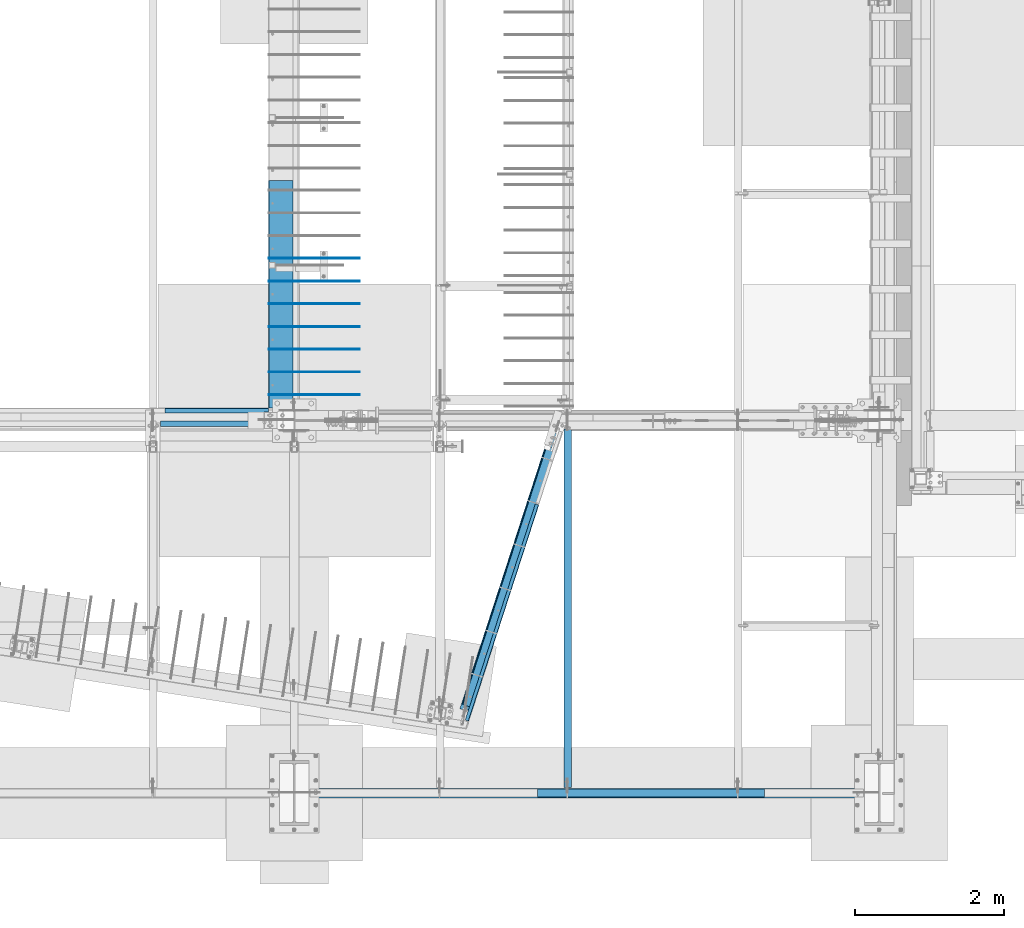
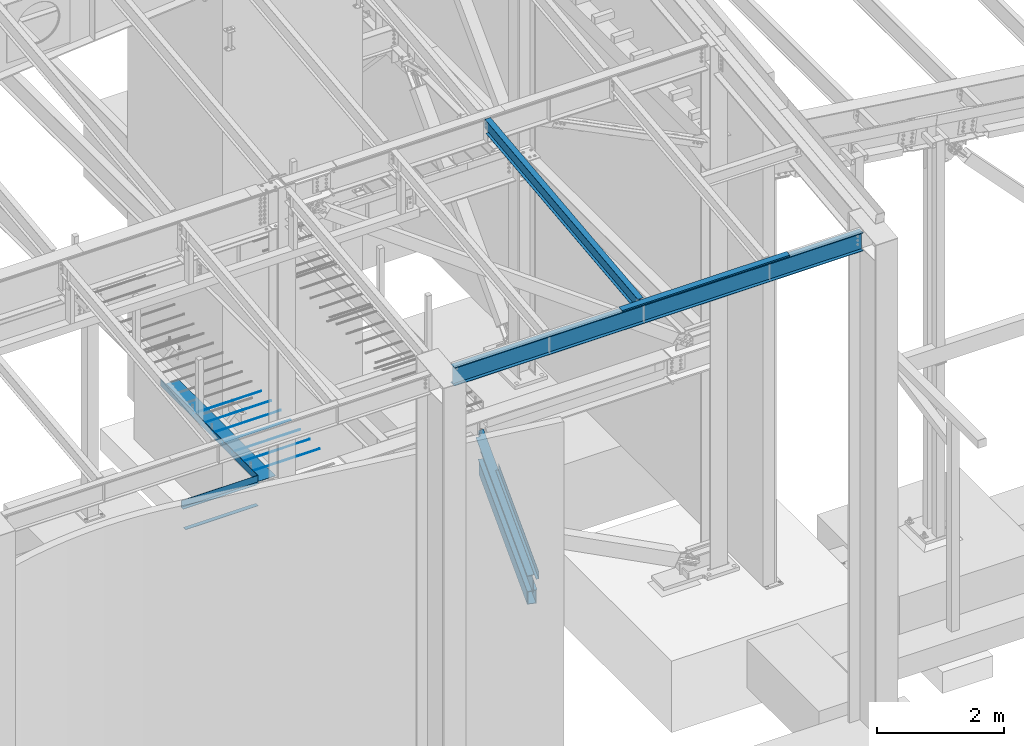
# One storey, part 714 of 1179: 16 beams, 13 elements without a shape of their own.
"""IFC2X3 building model written with IfcOpenShell, lengths in millimetres."""

from ifc_helpers import new_model, si_unit, frame, origin_with_axes, place, context, subcontext, project, spatial, faceted_brep, material, type_object, element, aggregate, save


model = new_model("IFC2X3")

# Units and contexts
model_context = context("Model", 3, precision=1e-05, world=origin_with_axes())
body_context = subcontext(model_context, "Body", "Model", "MODEL_VIEW")
ifc_project = project(units=[si_unit("LENGTHUNIT", "METRE", prefix="MILLI"), si_unit("AREAUNIT", "SQUARE_METRE"), si_unit("VOLUMEUNIT", "CUBIC_METRE"), si_unit("MASSUNIT", "GRAM", prefix="KILO"), si_unit("TIMEUNIT", "SECOND"), si_unit("PLANEANGLEUNIT", "RADIAN"), si_unit("SOLIDANGLEUNIT", "STERADIAN"), si_unit("THERMODYNAMICTEMPERATUREUNIT", "DEGREE_CELSIUS"), si_unit("LUMINOUSINTENSITYUNIT", "LUMEN")], contexts=[model_context])

# Site, building, storey
site_placement = place(None, origin_with_axes())
site = spatial("IfcSite", under=ifc_project, at=site_placement, CompositionType="ELEMENT")
building_placement = place(site_placement, origin_with_axes())
building = spatial("IfcBuilding", under=site, at=building_placement, Name="Undefined", CompositionType="ELEMENT")
storey_placement = place(building_placement, origin_with_axes())
storey = spatial("IfcBuildingStorey", under=building, at=storey_placement, Name="Undefined", CompositionType="ELEMENT", Elevation=0.0)

# Assembly, beam
assembly_1_placement = place(storey_placement, origin_with_axes())
assembly_1 = element("IfcElementAssembly", 1, at=assembly_1_placement, inside=storey, Name="BEAM", AssemblyPlace="NOTDEFINED", PredefinedType="RIGID_FRAME")
ifc_material_1 = material(Name="STEEL/A36")
beam_type_1 = type_object("IfcBeamType", PredefinedType="NOTDEFINED")
beam_1_placement = place(assembly_1_placement, frame((19222.5729576813, 2867.16417386917, 3851.275), z_axis=(0.308737244064257, 0.951147367197958, 0.0), x_axis=(0.951147370126809, -0.30873723504115, 0.0)))
beam_1 = element("IfcBeam", 2, at=beam_1_placement, type_object=beam_type_1, material=ifc_material_1, Name="BENT_PLATE", context=body_context, shape_type="Brep", body=[
    faceted_brep([(0.0, -3.17499999999927, -1524.0), (6.00266503170133e-10, -3.17499999922438, 1524.00000000052), (6.00266503170133e-10, 3.17500000077416, 1524.00000000052), (0.0, 3.17499999999927, -1524.0), (50.8000003793823, 3.17500000000018, 1524.00000000025), (50.8000003652887, 3.17500000000018, -1524.0000000005), (44.4500003652829, -3.17500000000018, -1524.00000000048), (44.4500003793801, -3.17500000000018, 1524.00000000027), (50.8000003777524, -130.175006110244, 1524.00000000011), (50.8000003669185, -130.175006107039, -1524.00000000063), (44.4500003777466, -130.175006110244, 1524.00000000013), (44.4500003669127, -130.175006107039, -1524.00000000062)], [[[0, 1, 2, 3]], [[3, 2, 4, 5]], [[1, 0, 6, 7]], [[5, 4, 8, 9]], [[4, 2, 1, 7, 10, 8]], [[7, 6, 11, 10]], [[6, 0, 3, 5, 9, 11]], [[10, 11, 9, 8]]]),
])

assembly_2_placement = place(storey_placement, origin_with_axes())
assembly_2 = element("IfcElementAssembly", 3, at=assembly_2_placement, inside=storey, Name="BEAM", AssemblyPlace="NOTDEFINED", PredefinedType="RIGID_FRAME")
ifc_material_2 = material(Name="STEEL/A992")
beam_type_2 = type_object("IfcBeamType", Name="W10X12", PredefinedType="NOTDEFINED")
beam_2_placement = place(assembly_2_placement, frame((20129.5, 452.231593993459, 9171.78056384809), z_axis=(-3.89779463887408e-08, -0.112282221021699, 0.993676357192035), x_axis=(0.0, 0.993676357192036, 0.112282221021699)))
beam_2 = element("IfcBeam", 4, at=beam_2_placement, type_object=beam_type_2, material=ifc_material_2, Name="BEAM", ObjectType="W10X12", context=body_context, shape_type="Brep", body=[
    faceted_brep([(4858.49015079339, 2.38124999999854, -120.649999999368), (4858.49015079341, 2.38119320135957, -125.412499999364), (4858.49013956012, 50.7999999999993, -125.412499999362), (4858.49013956012, 50.7999999999993, -120.649999999367), (4983.08589598448, 2.38124999999854, -120.649999999354), (4982.54774885665, 2.38122198294514, -125.412499999351), (48.8806597554974, -2.38124999999854, -120.649999999914), (48.8806597554974, -50.7999999999993, -120.649999999914), (4858.49016309746, -50.7999999999993, -120.649999999367), (4858.49015186424, -2.38124999999854, -120.649999999367), (76.1467808989316, 2.38124999999854, 120.649999999929), (76.1467808989316, 50.7999999999993, 120.649999999929), (4914.49585701086, 50.7999999999993, 120.650000000478), (4914.49585701086, 2.38124999999854, 120.650000000478), (48.3425126276663, -50.7999999999993, -125.412499999911), (76.1467808989316, -2.38124999999854, 120.649999999929), (76.1467808989316, -50.7999999999993, 120.649999999929), (76.6849280267622, -50.7999999999993, 125.412499999924), (76.6849280267622, 50.7999999999993, 125.412499999924), (48.8806597554974, 2.38124999999854, -120.649999999914), (48.8806597554974, 50.7999999999993, -120.649999999914), (48.3425126276663, 50.7999999999993, -125.412499999911), (4858.49016309746, -50.7999999999993, -125.412499999364), (4858.49015186426, -2.38130674932472, -125.412499999364), (4983.08589598448, -2.38124999999854, -120.649999999354), (4982.54774885665, -2.3812779679356, -125.412499999351), (4916.56631885514, -2.38124999999854, 69.1498492601459), (4912.78131142652, -2.38124999999854, 72.3480766489138), (4910.50832916744, -2.38124999999854, 76.7513131080195), (4910.0934130222, -2.38124999999854, 81.6892058020039), (4914.49585701086, -2.38124999999854, 120.650000000478), (4983.1719256045, -2.38124999999854, -119.888654181221), (5003.31510185873, -2.38124999999854, 58.3746347029464), (4921.28711838346, -2.38124999999854, 67.6435320696546), (4914.49585701086, -50.7999999999993, 120.650000000478), (4915.03400413869, -50.7999999999993, 125.412500000475), (4915.03400413869, 50.7999999999993, 125.412500000475), (4910.0934130222, 2.38124999999854, 81.6892058020039), (4910.50832916744, 2.38124999999854, 76.7513131080195), (4912.78131142652, 2.38124999999854, 72.3480766489138), (4916.56631885514, 2.38124999999854, 69.1498492601459), (4921.28711838346, 2.38124999999854, 67.6435320696546), (5003.31510185873, 2.38124999999854, 58.3746347029464), (4983.17191277243, 2.38124999999854, -119.888767742599)], [[[0, 1, 2, 3]], [[4, 5, 1, 0]], [[6, 7, 8, 9]], [[10, 11, 12, 13]], [[14, 7, 6, 15, 16, 17, 18, 11, 10, 19, 20, 21]], [[7, 14, 22, 8]], [[8, 22, 23, 9]], [[24, 9, 23, 25]], [[26, 27, 28, 29, 30, 15, 6, 9, 24, 31, 32, 33]], [[16, 15, 30, 34]], [[17, 16, 34, 35]], [[18, 17, 35, 36]], [[11, 18, 36, 12]], [[35, 34, 30, 29, 37, 13, 12, 36]], [[28, 38, 37, 29]], [[27, 39, 38, 28]], [[26, 40, 39, 27]], [[33, 41, 40, 26]], [[32, 42, 41, 33]], [[43, 4, 0, 19, 10, 13, 37, 38, 39, 40, 41, 42]], [[20, 19, 0, 3]], [[21, 20, 3, 2]], [[25, 23, 22, 14, 21, 2, 1, 5]], [[43, 42, 32, 31, 24, 25, 5, 4]]]),
])
aggregate(assembly_2, [beam_2])

assembly_3_placement = place(storey_placement, origin_with_axes())
assembly_3 = element("IfcElementAssembly", 5, at=assembly_3_placement, inside=storey, Name="BEAM", AssemblyPlace="NOTDEFINED", PredefinedType="RIGID_FRAME")
beam_type_3 = type_object("IfcBeamType", Name="W14X22", PredefinedType="NOTDEFINED")
beam_3_placement = place(assembly_3_placement, frame((16459.2, 438.14999988271, 9090.63466887871), z_axis=(0.0, 0.0, 1.0), x_axis=(1.0, 0.0, 0.0)))
beam_3 = element("IfcBeam", 6, at=beam_3_placement, type_object=beam_type_3, material=ifc_material_2, Name="BEAM", ObjectType="W14X22", context=body_context, shape_type="Brep", body=[
    faceted_brep([(212.725000000002, -63.5, -174.625), (212.725000000002, 63.5, -174.625), (7635.875, 63.5, -174.625), (7635.875, -63.5, -174.625), (212.725000000002, -63.5, -166.6875), (212.725000000002, -3.17500000000001, -166.6875), (212.725000000002, -3.17500000000001, 166.6875), (212.725000000002, -63.5, 166.6875), (212.725000000002, -63.5, 174.625), (212.725000000002, 63.5, 174.625), (212.725000000002, 63.5, 166.6875), (212.725000000002, 3.17500000000001, 166.6875), (212.725000000002, 3.17500000000001, 137.265000000092), (212.725000000002, 3.17500000000001, -92.8149999999841), (212.725000000002, 3.17500000000001, -166.6875), (212.725000000002, 63.5, -166.6875), (7635.875, -63.5, -166.6875), (7635.875, -3.17500000000001, -166.6875), (7635.875, -3.17500000000001, 166.6875), (7635.875, -63.5, 166.6875), (7635.875, -63.5, 174.625), (7635.875, 63.5, 174.625), (7635.875, 63.5, 166.6875), (7635.875, 3.17500000000001, 166.6875), (7635.875, 3.17500000000001, 137.26500000009), (7635.875, 3.17500000000001, -92.814999999986), (7635.875, 3.17500000000001, -166.6875), (7635.875, 63.5, -166.6875)], [[[0, 1, 2, 3]], [[0, 4, 5, 6, 7, 8, 9, 10, 11, 12, 13, 14, 15, 1]], [[5, 4, 16, 17]], [[6, 5, 17, 18]], [[7, 6, 18, 19]], [[8, 7, 19, 20]], [[9, 8, 20, 21]], [[10, 9, 21, 22]], [[11, 10, 22, 23]], [[14, 13, 12, 11, 23, 24, 25, 26]], [[15, 14, 26, 27]], [[1, 15, 27, 2]], [[26, 25, 24, 23, 22, 21, 20, 19, 18, 17, 16, 3, 2, 27]], [[4, 0, 3, 16]]]),
])

assembly_4_placement = place(storey_placement, origin_with_axes())
assembly_4 = element("IfcElementAssembly", 7, at=assembly_4_placement, inside=storey, Name="BEAM", AssemblyPlace="NOTDEFINED", PredefinedType="RIGID_FRAME")
beam_type_4 = type_object("IfcBeamType", PredefinedType="NOTDEFINED")
beam_4_placement = place(assembly_4_placement, frame((15417.8, 5597.525, 4235.45000610352), z_axis=(1.0, 0.0, 0.0), x_axis=(0.0, 0.0, -1.0)))
beam_4 = element("IfcBeam", 8, at=beam_4_placement, type_object=beam_type_4, material=ifc_material_1, Name="BENT_PLATE", context=body_context, shape_type="Brep", body=[
    faceted_brep([(133.350006103516, -60.3250000000016, 635.000000000004), (133.350006103516, -47.6250000000027, 635.000000000004), (127.000006103515, -47.6250000000027, 635.000000000004), (127.000006103515, -60.3250000000016, 635.000000000004), (133.350006103516, -47.6250000000027, 695.325000000001), (127.000006103515, -47.6250000000027, 695.325000000001), (127.000006103515, -3.17500000000018, -695.325000000001), (0.0, -3.17499999999927, -695.325000000001), (0.0, 3.17499999999927, -695.325000000001), (133.350006103516, 3.17500000000018, -695.325000000001), (133.350006103516, -60.3250000000016, -695.325000000001), (127.000006103515, -60.3250000000016, -695.325000000001), (0.0, -3.17499999999927, 695.325000000001), (127.000006103515, -3.17500000000018, 695.325000000001), (0.0, 3.17499999999927, 695.325000000001), (133.350006103516, 3.17500000000018, 695.325000000001)], [[[0, 1, 2, 3]], [[4, 5, 2, 1]], [[6, 7, 8, 9, 10, 11]], [[12, 7, 6, 13]], [[7, 12, 14, 8]], [[8, 14, 15, 9]], [[0, 10, 9, 15, 4, 1]], [[11, 10, 0, 3]], [[13, 6, 11, 3, 2, 5]], [[15, 14, 12, 13, 5, 4]]]),
])

# Beam
beam_type_5 = type_object("IfcBeamType", PredefinedType="NOTDEFINED")
beam_5_placement = place(assembly_3_placement, frame((21243.9249999995, 485.774999119674, 9265.25966886781), z_axis=(-1.0, 0.0, 0.0), x_axis=(0.0, 0.0, 1.0)))
beam_5 = element("IfcBeam", 9, at=beam_5_placement, type_object=beam_type_5, material=ifc_material_1, Name="BENT_PLATE", context=body_context, shape_type="Brep", body=[
    faceted_brep([(0.0, -3.17499999999927, -1524.0), (6.00266503170133e-10, -3.17499999922438, 1524.00000000052), (6.00266503170133e-10, 3.17500000077416, 1524.00000000052), (0.0, 3.17499999999927, -1524.0), (36.8806648358295, 3.17499999974928, 1524.0), (36.8806648358295, 3.17499999974928, -1524.0), (29.7727112184712, -3.17500000020243, -1524.0), (29.7727112184712, -3.17500000020243, 1524.0), (25.3999996289767, -98.4249984738682, 1524.0), (25.3999996289767, -98.4249984738682, -1524.0), (19.7271291840298, -92.0749984738682, -1524.0), (19.7271291840298, -92.0749984738682, 1524.0), (2.13476596400142e-08, -98.4249984738682, 1524.0), (2.13476596400142e-08, -98.4249984738682, -1524.0), (2.13476596400142e-08, -92.0749984738682, 1524.0), (2.13476596400142e-08, -92.0749984738682, -1524.0)], [[[0, 1, 2, 3]], [[3, 2, 4, 5]], [[1, 0, 6, 7]], [[5, 4, 8, 9]], [[7, 6, 10, 11]], [[9, 8, 12, 13]], [[8, 4, 2, 1, 7, 11, 14, 12]], [[11, 10, 15, 14]], [[10, 6, 0, 3, 5, 9, 13, 15]], [[14, 15, 13, 12]]]),
])

aggregate(assembly_3, [beam_5, beam_3])

# Assembly, beam
assembly_5_placement = place(storey_placement, origin_with_axes())
assembly_5 = element("IfcElementAssembly", 10, at=assembly_5_placement, inside=storey, Name="BEAM", AssemblyPlace="NOTDEFINED", PredefinedType="RIGID_FRAME")
ifc_material_3 = material()
beam_type_6 = type_object("IfcBeamType", Name="HSS12X6X3/8", PredefinedType="NOTDEFINED")
beam_6_placement = place(assembly_5_placement, frame((18786.0385556772, 1604.5550530891, 3403.6), z_axis=(0.0, 0.0, 1.0), x_axis=(0.308737244064257, 0.951147367197958, 0.0)))
beam_6 = element("IfcBeam", 11, at=beam_6_placement, type_object=beam_type_6, material=ifc_material_3, Name="BEAM", ObjectType="HSS12X6X3/8", context=body_context, shape_type="Brep", body=[
    faceted_brep([(3645.75871539982, -66.6750000099128, 133.350000000671), (1.54614099301398e-11, -66.6750000000611, 133.35), (1.72803993336856e-11, -76.2000000000662, 123.82500038214), (3645.75871539982, -76.2000000026783, 123.82500038214), (1.72803993336856e-11, -76.2000000000662, -152.4), (-1.54614099301398e-11, 76.2000000000662, -152.4), (3645.75871539979, 76.1999999974578, -152.4), (3645.75871539982, -76.2000000026783, -152.4), (-1.54614099301398e-11, 76.2000000000662, 133.35), (3645.75871539979, 76.1999999974578, 133.35), (-1.36424205265939e-11, 66.6750000000575, 133.35), (3645.75871539979, 66.6749999974527, 133.35), (-1.36424205265939e-11, 66.6750000000575, -142.875), (3645.75871539979, 66.6749999974527, -142.875), (1.54614099301398e-11, -66.6750000000611, -142.875), (3645.75871539982, -66.6750000026695, -142.875)], [[[0, 1, 2, 3]], [[4, 5, 6, 7]], [[6, 5, 8, 9]], [[8, 10, 11, 9]], [[12, 13, 11, 10]], [[12, 14, 15, 13]], [[7, 6, 9, 11, 13, 15, 0, 3]], [[4, 7, 3, 2]], [[14, 12, 10, 8, 5, 4, 2, 1]], [[15, 14, 1, 0]]]),
])
aggregate(assembly_5, [beam_6])

# Beam
beam_type_7 = type_object("IfcBeamType", PredefinedType="NOTDEFINED")
beam_7_placement = place(assembly_4_placement, frame((14665.325, 5390.35625, 3844.13073387436), z_axis=(0.0, 1.0, 0.0), x_axis=(1.0, 0.0, 0.0)))
beam_7 = element("IfcBeam", 12, at=beam_7_placement, type_object=beam_type_7, material=ifc_material_1, Name="PLATE", context=body_context, shape_type="Brep", body=[
    faceted_brep([(0.0, 3.96900000000005, -38.1000000000004), (0.0, 3.96900000000005, 38.1000000000004), (1317.62499542855, 3.96899999977632, 38.1000000000004), (1317.62499542855, 3.96899999977632, -38.1000000000004), (-3.63797880709171e-12, -3.96900000000005, 38.1000000000004), (1317.62499542856, -3.96900000022333, 38.1000000000004), (-3.63797880709171e-12, -3.96900000000005, -38.1000000000004), (1317.62499542856, -3.96900000022333, -38.1000000000004)], [[[0, 1, 2, 3]], [[1, 4, 5, 2]], [[4, 6, 7, 5]], [[6, 0, 3, 7]], [[5, 7, 3, 2]], [[6, 4, 1, 0]]]),
])

aggregate(assembly_4, [beam_4, beam_7])

# Assembly, beam
assembly_6_placement = place(storey_placement, origin_with_axes())
assembly_6 = element("IfcElementAssembly", 13, at=assembly_6_placement, inside=storey, Name="#4 DOWEL", AssemblyPlace="NOTDEFINED", PredefinedType="NOTDEFINED")
ifc_material_4 = material(Name="REBAR/A615-40")
beam_type_8 = type_object("IfcBeamType", Name="#4 DOWEL", PredefinedType="NOTDEFINED")
beam_8_placement = place(assembly_6_placement, frame((16119.475, 7610.475, 4203.70000610352), z_axis=(0.0, 0.0, 1.0), x_axis=(1.0, 0.0, 0.0)))
beam_8 = element("IfcBeam", 14, at=beam_8_placement, type_object=beam_type_8, material=ifc_material_4, Name="#4 DOWEL", ObjectType="#4 DOWEL", context=body_context, shape_type="Brep", body=[
    faceted_brep([(0.0, -6.34999999999854, 0.0), (0.0, -4.49012806053361, -4.49012806053452), (1219.2, -4.49012806053543, -4.49012806053452), (1219.2, -6.35000000000036, 0.0), (0.0, 0.0, -6.34999999999991), (1219.2, 0.0, -6.35000000000036), (0.0, 4.49012806053361, -4.49012806053452), (1219.2, 4.49012806053543, -4.49012806053452), (0.0, 6.34999999999854, 0.0), (1219.2, 6.35000000000036, 0.0), (0.0, 4.49012806053361, 4.49012806053452), (1219.2, 4.49012806053543, 4.49012806053452), (0.0, 0.0, 6.34999999999991), (1219.2, 0.0, 6.35000000000036), (0.0, -4.49012806053361, 4.49012806053452), (1219.2, -4.49012806053543, 4.49012806053452)], [[[0, 1, 2, 3]], [[1, 4, 5, 2]], [[4, 6, 7, 5]], [[6, 8, 9, 7]], [[8, 10, 11, 9]], [[10, 12, 13, 11]], [[12, 14, 15, 13]], [[14, 0, 3, 15]], [[5, 7, 9, 11, 13, 15, 3, 2]], [[14, 12, 10, 8, 6, 4, 1, 0]]]),
])
aggregate(assembly_6, [beam_8])

assembly_7_placement = place(storey_placement, origin_with_axes())
assembly_7 = element("IfcElementAssembly", 15, at=assembly_7_placement, inside=storey, Name="#4 DOWEL", AssemblyPlace="NOTDEFINED", PredefinedType="NOTDEFINED")
beam_9_placement = place(assembly_7_placement, frame((16119.475, 7305.675, 4203.70000610352), z_axis=(0.0, 0.0, 1.0), x_axis=(1.0, 0.0, 0.0)))
beam_9 = element("IfcBeam", 16, at=beam_9_placement, type_object=beam_type_8, material=ifc_material_4, Name="#4 DOWEL", ObjectType="#4 DOWEL", context=body_context, shape_type="Brep", body=[
    faceted_brep([(0.0, -6.34999999999854, 0.0), (0.0, -4.49012806053361, -4.49012806053452), (1219.2, -4.49012806053543, -4.49012806053452), (1219.2, -6.35000000000036, 0.0), (0.0, 0.0, -6.34999999999991), (1219.2, 0.0, -6.35000000000036), (0.0, 4.49012806053361, -4.49012806053452), (1219.2, 4.49012806053543, -4.49012806053452), (0.0, 6.34999999999854, 0.0), (1219.2, 6.35000000000036, 0.0), (0.0, 4.49012806053361, 4.49012806053452), (1219.2, 4.49012806053543, 4.49012806053452), (0.0, 0.0, 6.34999999999991), (1219.2, 0.0, 6.35000000000036), (0.0, -4.49012806053361, 4.49012806053452), (1219.2, -4.49012806053543, 4.49012806053452)], [[[0, 1, 2, 3]], [[1, 4, 5, 2]], [[4, 6, 7, 5]], [[6, 8, 9, 7]], [[8, 10, 11, 9]], [[10, 12, 13, 11]], [[12, 14, 15, 13]], [[14, 0, 3, 15]], [[5, 7, 9, 11, 13, 15, 3, 2]], [[14, 12, 10, 8, 6, 4, 1, 0]]]),
])
aggregate(assembly_7, [beam_9])

assembly_8_placement = place(storey_placement, origin_with_axes())
assembly_8 = element("IfcElementAssembly", 17, at=assembly_8_placement, inside=storey, Name="#4 DOWEL", AssemblyPlace="NOTDEFINED", PredefinedType="NOTDEFINED")
beam_10_placement = place(assembly_8_placement, frame((16119.475, 7000.875, 4203.70000610352), z_axis=(0.0, 0.0, 1.0), x_axis=(1.0, 0.0, 0.0)))
beam_10 = element("IfcBeam", 18, at=beam_10_placement, type_object=beam_type_8, material=ifc_material_4, Name="#4 DOWEL", ObjectType="#4 DOWEL", context=body_context, shape_type="Brep", body=[
    faceted_brep([(0.0, -6.34999999999854, 0.0), (0.0, -4.49012806053361, -4.49012806053452), (1219.2, -4.49012806053543, -4.49012806053452), (1219.2, -6.35000000000036, 0.0), (0.0, 0.0, -6.34999999999991), (1219.2, 0.0, -6.35000000000036), (0.0, 4.49012806053361, -4.49012806053452), (1219.2, 4.49012806053543, -4.49012806053452), (0.0, 6.34999999999854, 0.0), (1219.2, 6.35000000000036, 0.0), (0.0, 4.49012806053361, 4.49012806053452), (1219.2, 4.49012806053543, 4.49012806053452), (0.0, 0.0, 6.34999999999991), (1219.2, 0.0, 6.35000000000036), (0.0, -4.49012806053361, 4.49012806053452), (1219.2, -4.49012806053543, 4.49012806053452)], [[[0, 1, 2, 3]], [[1, 4, 5, 2]], [[4, 6, 7, 5]], [[6, 8, 9, 7]], [[8, 10, 11, 9]], [[10, 12, 13, 11]], [[12, 14, 15, 13]], [[14, 0, 3, 15]], [[5, 7, 9, 11, 13, 15, 3, 2]], [[14, 12, 10, 8, 6, 4, 1, 0]]]),
])
aggregate(assembly_8, [beam_10])

assembly_9_placement = place(storey_placement, origin_with_axes())
assembly_9 = element("IfcElementAssembly", 19, at=assembly_9_placement, inside=storey, Name="#4 DOWEL", AssemblyPlace="NOTDEFINED", PredefinedType="NOTDEFINED")
beam_11_placement = place(assembly_9_placement, frame((16119.475, 6696.075, 4203.70000610352), z_axis=(0.0, 0.0, 1.0), x_axis=(1.0, 0.0, 0.0)))
beam_11 = element("IfcBeam", 20, at=beam_11_placement, type_object=beam_type_8, material=ifc_material_4, Name="#4 DOWEL", ObjectType="#4 DOWEL", context=body_context, shape_type="Brep", body=[
    faceted_brep([(0.0, -6.34999999999854, 0.0), (0.0, -4.49012806053361, -4.49012806053452), (1219.2, -4.49012806053543, -4.49012806053452), (1219.2, -6.35000000000036, 0.0), (0.0, 0.0, -6.34999999999991), (1219.2, 0.0, -6.35000000000036), (0.0, 4.49012806053361, -4.49012806053452), (1219.2, 4.49012806053543, -4.49012806053452), (0.0, 6.34999999999854, 0.0), (1219.2, 6.35000000000036, 0.0), (0.0, 4.49012806053361, 4.49012806053452), (1219.2, 4.49012806053543, 4.49012806053452), (0.0, 0.0, 6.34999999999991), (1219.2, 0.0, 6.35000000000036), (0.0, -4.49012806053361, 4.49012806053452), (1219.2, -4.49012806053543, 4.49012806053452)], [[[0, 1, 2, 3]], [[1, 4, 5, 2]], [[4, 6, 7, 5]], [[6, 8, 9, 7]], [[8, 10, 11, 9]], [[10, 12, 13, 11]], [[12, 14, 15, 13]], [[14, 0, 3, 15]], [[5, 7, 9, 11, 13, 15, 3, 2]], [[14, 12, 10, 8, 6, 4, 1, 0]]]),
])
aggregate(assembly_9, [beam_11])

assembly_10_placement = place(storey_placement, origin_with_axes())
assembly_10 = element("IfcElementAssembly", 21, at=assembly_10_placement, inside=storey, Name="#4 DOWEL", AssemblyPlace="NOTDEFINED", PredefinedType="NOTDEFINED")
beam_12_placement = place(assembly_10_placement, frame((16119.475, 6391.275, 4203.70000610352), z_axis=(0.0, 0.0, 1.0), x_axis=(1.0, 0.0, 0.0)))
beam_12 = element("IfcBeam", 22, at=beam_12_placement, type_object=beam_type_8, material=ifc_material_4, Name="#4 DOWEL", ObjectType="#4 DOWEL", context=body_context, shape_type="Brep", body=[
    faceted_brep([(0.0, -6.34999999999854, 0.0), (0.0, -4.49012806053361, -4.49012806053452), (1219.2, -4.49012806053543, -4.49012806053452), (1219.2, -6.35000000000036, 0.0), (0.0, 0.0, -6.34999999999991), (1219.2, 0.0, -6.35000000000036), (0.0, 4.49012806053361, -4.49012806053452), (1219.2, 4.49012806053543, -4.49012806053452), (0.0, 6.34999999999854, 0.0), (1219.2, 6.35000000000036, 0.0), (0.0, 4.49012806053361, 4.49012806053452), (1219.2, 4.49012806053543, 4.49012806053452), (0.0, 0.0, 6.34999999999991), (1219.2, 0.0, 6.35000000000036), (0.0, -4.49012806053361, 4.49012806053452), (1219.2, -4.49012806053543, 4.49012806053452)], [[[0, 1, 2, 3]], [[1, 4, 5, 2]], [[4, 6, 7, 5]], [[6, 8, 9, 7]], [[8, 10, 11, 9]], [[10, 12, 13, 11]], [[12, 14, 15, 13]], [[14, 0, 3, 15]], [[5, 7, 9, 11, 13, 15, 3, 2]], [[14, 12, 10, 8, 6, 4, 1, 0]]]),
])
aggregate(assembly_10, [beam_12])

assembly_11_placement = place(storey_placement, origin_with_axes())
assembly_11 = element("IfcElementAssembly", 23, at=assembly_11_placement, inside=storey, Name="#4 DOWEL", AssemblyPlace="NOTDEFINED", PredefinedType="NOTDEFINED")
beam_13_placement = place(assembly_11_placement, frame((16119.475, 6086.475, 4203.70000610352), z_axis=(0.0, 0.0, 1.0), x_axis=(1.0, 0.0, 0.0)))
beam_13 = element("IfcBeam", 24, at=beam_13_placement, type_object=beam_type_8, material=ifc_material_4, Name="#4 DOWEL", ObjectType="#4 DOWEL", context=body_context, shape_type="Brep", body=[
    faceted_brep([(0.0, -6.34999999999854, 0.0), (0.0, -4.49012806053361, -4.49012806053452), (1219.2, -4.49012806053543, -4.49012806053452), (1219.2, -6.35000000000036, 0.0), (0.0, 0.0, -6.34999999999991), (1219.2, 0.0, -6.35000000000036), (0.0, 4.49012806053361, -4.49012806053452), (1219.2, 4.49012806053543, -4.49012806053452), (0.0, 6.34999999999854, 0.0), (1219.2, 6.35000000000036, 0.0), (0.0, 4.49012806053361, 4.49012806053452), (1219.2, 4.49012806053543, 4.49012806053452), (0.0, 0.0, 6.34999999999991), (1219.2, 0.0, 6.35000000000036), (0.0, -4.49012806053361, 4.49012806053452), (1219.2, -4.49012806053543, 4.49012806053452)], [[[0, 1, 2, 3]], [[1, 4, 5, 2]], [[4, 6, 7, 5]], [[6, 8, 9, 7]], [[8, 10, 11, 9]], [[10, 12, 13, 11]], [[12, 14, 15, 13]], [[14, 0, 3, 15]], [[5, 7, 9, 11, 13, 15, 3, 2]], [[14, 12, 10, 8, 6, 4, 1, 0]]]),
])
aggregate(assembly_11, [beam_13])

assembly_12_placement = place(storey_placement, origin_with_axes())
assembly_12 = element("IfcElementAssembly", 25, at=assembly_12_placement, inside=storey, Name="#4 DOWEL", AssemblyPlace="NOTDEFINED", PredefinedType="NOTDEFINED")
beam_14_placement = place(assembly_12_placement, frame((16119.475, 5781.675, 4203.70000610352), z_axis=(0.0, 0.0, 1.0), x_axis=(1.0, 0.0, 0.0)))
beam_14 = element("IfcBeam", 26, at=beam_14_placement, type_object=beam_type_8, material=ifc_material_4, Name="#4 DOWEL", ObjectType="#4 DOWEL", context=body_context, shape_type="Brep", body=[
    faceted_brep([(0.0, -6.34999999999854, 0.0), (0.0, -4.49012806053361, -4.49012806053452), (1219.2, -4.49012806053543, -4.49012806053452), (1219.2, -6.35000000000036, 0.0), (0.0, 0.0, -6.34999999999991), (1219.2, 0.0, -6.35000000000036), (0.0, 4.49012806053361, -4.49012806053452), (1219.2, 4.49012806053543, -4.49012806053452), (0.0, 6.34999999999854, 0.0), (1219.2, 6.35000000000036, 0.0), (0.0, 4.49012806053361, 4.49012806053452), (1219.2, 4.49012806053543, 4.49012806053452), (0.0, 0.0, 6.34999999999991), (1219.2, 0.0, 6.35000000000036), (0.0, -4.49012806053361, 4.49012806053452), (1219.2, -4.49012806053543, 4.49012806053452)], [[[0, 1, 2, 3]], [[1, 4, 5, 2]], [[4, 6, 7, 5]], [[6, 8, 9, 7]], [[8, 10, 11, 9]], [[10, 12, 13, 11]], [[12, 14, 15, 13]], [[14, 0, 3, 15]], [[5, 7, 9, 11, 13, 15, 3, 2]], [[14, 12, 10, 8, 6, 4, 1, 0]]]),
])
aggregate(assembly_12, [beam_14])

assembly_13_placement = place(storey_placement, origin_with_axes())
assembly_13 = element("IfcElementAssembly", 27, at=assembly_13_placement, inside=storey, Name="BEAM", AssemblyPlace="NOTDEFINED", PredefinedType="RIGID_FRAME")
beam_type_9 = type_object("IfcBeamType", PredefinedType="NOTDEFINED")
beam_15_placement = place(assembly_13_placement, frame((16443.325012207, 7129.4625, 4105.27500000003), z_axis=(0.0, -1.0, 0.0), x_axis=(-1.0, 0.0, 0.0)))
beam_15 = element("IfcBeam", 28, at=beam_15_placement, type_object=beam_type_9, material=ifc_material_1, Name="BENT_PLATE", context=body_context, shape_type="Brep", body=[
    faceted_brep([(0.0, -3.17499999999927, -1524.0), (6.00266503170133e-10, -3.17499999922438, 1524.00000000052), (6.00266503170133e-10, 3.17500000077416, 1524.00000000052), (0.0, 3.17499999999927, -1524.0), (330.200012207031, 3.17500000000018, 1524.0), (330.200012207031, 3.17500000000018, -1524.0), (323.850012207033, -3.17500000000018, -1524.0), (323.850012207033, -3.17500000000018, 1524.0), (330.200012207031, -130.175006103515, 1524.0), (330.200012207031, -130.175006103515, -1524.0), (323.850012207033, -130.175006103515, 1524.0), (323.850012207033, -130.175006103515, -1524.0)], [[[0, 1, 2, 3]], [[3, 2, 4, 5]], [[1, 0, 6, 7]], [[5, 4, 8, 9]], [[4, 2, 1, 7, 10, 8]], [[7, 6, 11, 10]], [[6, 0, 3, 5, 9, 11]], [[10, 11, 9, 8]]]),
])
aggregate(assembly_13, [beam_15])

# Beam
beam_type_10 = type_object("IfcBeamType", Name="W12X26", PredefinedType="NOTDEFINED")
beam_16_placement = place(assembly_1_placement, frame((18731.7881471654, 1457.98997930767, 3692.525), z_axis=(0.0, 0.0, 1.0), x_axis=(0.308737244064257, 0.951147367197958, 0.0)))
beam_16 = element("IfcBeam", 29, at=beam_16_placement, type_object=beam_type_10, material=ifc_material_2, Name="BEAM", ObjectType="W12X26", context=body_context, shape_type="Brep", body=[
    faceted_brep([(18.1820454734243, -3.17500000000655, -127.0), (18.1820454737071, 3.17499999999927, -127.0), (86.2790589453562, 3.17511524581278, -127.0), (87.2848183922906, -3.174999999992, -127.0), (91.1997198419276, 3.17511602705417, -127.966729922588), (92.2054794125997, -3.17499999999563, -127.966729922588), (95.3712544774917, 3.17511823878522, -130.719743823065), (96.3770143984675, -3.174999999992, -130.719743823065), (98.1585845188438, 3.17512154428186, -134.839920291217), (99.1643449633584, -3.174999999992, -134.839920291217), (99.1373642343951, 3.17512544031706, -139.699999809262), (100.143125295983, -3.174999999992, -139.699999809262), (112.714890218523, -82.5500000000829, -146.05), (100.143125296217, -3.174999999992, -146.05), (99.1373058014506, 3.17549437296475, -146.05), (86.5656191801281, 82.5500000001048, -146.05), (86.5656191797652, 82.5500000001048, -155.575), (112.714890218411, -82.5500000000829, -155.575), (3979.71279754246, 82.5500000007378, 146.05), (3979.71279970997, 28.5749996397753, 146.05), (3981.64625994549, 18.8548406812915, 146.05), (3987.15228807735, 10.6144879660606, 146.05), (3995.39264123476, 5.10846049598695, 146.05), (4005.11280034849, 3.17500000065047, 146.05), (99.1468418440309, 3.17500000001382, 146.05), (86.5891635331336, 82.5500000001084, 146.05), (87.2935015936309, -3.17499999999563, 123.825), (86.2889002641878, 3.17491823728778, 123.825), (18.1820454737071, 3.17499999999927, 123.825), (18.1820454734243, -3.17500000000655, 123.825), (92.2140277607605, -3.17499999999563, 124.791729922588), (91.2094265531796, 3.17491746701489, 124.791729922588), (96.3854484236253, -3.174999999992, 127.544743823066), (95.3808475631249, 3.17491527317907, 127.544743823066), (99.1727026003264, -3.174999999992, 131.66492029122), (98.1681022592838, 3.17491198977223, 131.66492029122), (100.151456108984, -3.174999999992, 136.524999809265), (99.146856380693, 3.17490811667085, 136.524999809265), (4174.4873675164, -82.5499999994208, 155.575), (4146.66150068109, 3.17500672522146, 155.575), (4005.11280034849, 3.17500104113424, 155.575), (3995.39264123476, 5.10846049598695, 155.575), (3987.15228807735, 10.6144879660606, 155.575), (3981.64625994549, 18.8548406812915, 155.575), (3979.71279970997, 28.5749996397753, 155.575), (3979.71279754246, 82.5500000007378, 155.575), (86.5891635331336, 82.5500000001084, 155.575), (112.709134419802, -82.5500000000829, 155.575), (4174.4873675164, -82.5499999994208, 146.05), (112.709134419802, -82.5500000000829, 146.05), (4148.72267802351, -3.17499999933352, 146.05), (100.151456108904, -3.17499999998836, 146.05), (4146.66150286408, 3.1750000006723, 146.05), (4148.72267802351, -3.17499999933352, -31.75), (4146.66150286408, 3.1750000006723, -31.75), (4005.11281128782, -3.17499999935535, -31.75), (4005.11281097455, 3.17500000065047, -31.75), (3995.39265225174, -3.17499999935899, -33.6834598451755), (3995.39265193846, 3.17500000065047, -33.6834598451755), (3987.15229931543, -3.17499999935899, -39.189487646132), (3987.15229900216, 3.17500000064683, -39.189487646132), (3981.64627151448, -3.17499999935899, -47.4298405824393), (3981.6462712012, 3.17500000064683, -47.4298405824393), (3979.7128116693, -3.17499999936263, -57.1499996185303), (3979.71281135603, 3.17500000064683, -57.1499996185303), (3801.91281100452, 3.17500000061773, -146.05), (3801.91281100452, 3.17500255975756, -155.575), (3801.91282023936, 82.5500000007123, -155.575), (3801.91282023936, 82.5500000007123, -146.05), (3979.71281190186, 3.17500079462116, -146.05), (3979.71281135603, 3.17500079462116, -155.575), (3979.71281135604, 3.17500000064683, -63.4999999999759), (3979.71281166949, -3.17499999935899, -146.05), (3979.71281558558, -82.5499999994499, -146.05), (3979.71281558522, -82.5499999994536, -155.575)], [[[0, 1, 2, 3]], [[3, 2, 4, 5]], [[5, 4, 6, 7]], [[7, 6, 8, 9]], [[9, 8, 10, 11]], [[12, 13, 11, 10, 14, 15, 16, 17]], [[18, 19, 20, 21, 22, 23, 24, 25]], [[26, 27, 28, 29]], [[30, 31, 27, 26]], [[32, 33, 31, 30]], [[34, 35, 33, 32]], [[36, 37, 35, 34]], [[38, 39, 40, 41, 42, 43, 44, 45, 46, 47]], [[48, 38, 47, 49]], [[50, 48, 49, 51]], [[47, 46, 25, 24, 37, 36, 51, 49]], [[45, 18, 25, 46]], [[44, 19, 18, 45]], [[43, 20, 19, 44]], [[42, 21, 20, 43]], [[41, 22, 21, 42]], [[40, 23, 22, 41]], [[39, 52, 23, 40]], [[38, 48, 50, 53, 54, 52, 39]], [[53, 55, 56, 54]], [[57, 58, 56, 55]], [[59, 60, 58, 57]], [[61, 62, 60, 59]], [[63, 64, 62, 61]], [[65, 66, 67, 68]], [[69, 70, 66, 65]], [[71, 64, 63, 72, 73, 74, 70, 69]], [[74, 73, 12, 17]], [[67, 66, 70, 74, 17, 16]], [[68, 67, 16, 15]], [[65, 68, 15, 14]], [[6, 4, 2, 1, 28, 27, 31, 33, 35, 37, 24, 23, 52, 54, 56, 58, 60, 62, 64, 71, 69, 65, 14, 10, 8]], [[29, 28, 1, 0]], [[72, 63, 61, 59, 57, 55, 53, 50, 51, 36, 34, 32, 30, 26, 29, 0, 3, 5, 7, 9, 11, 13]], [[73, 72, 13, 12]]]),
])

aggregate(assembly_1, [beam_1, beam_16])

save(model, "model.ifc")
